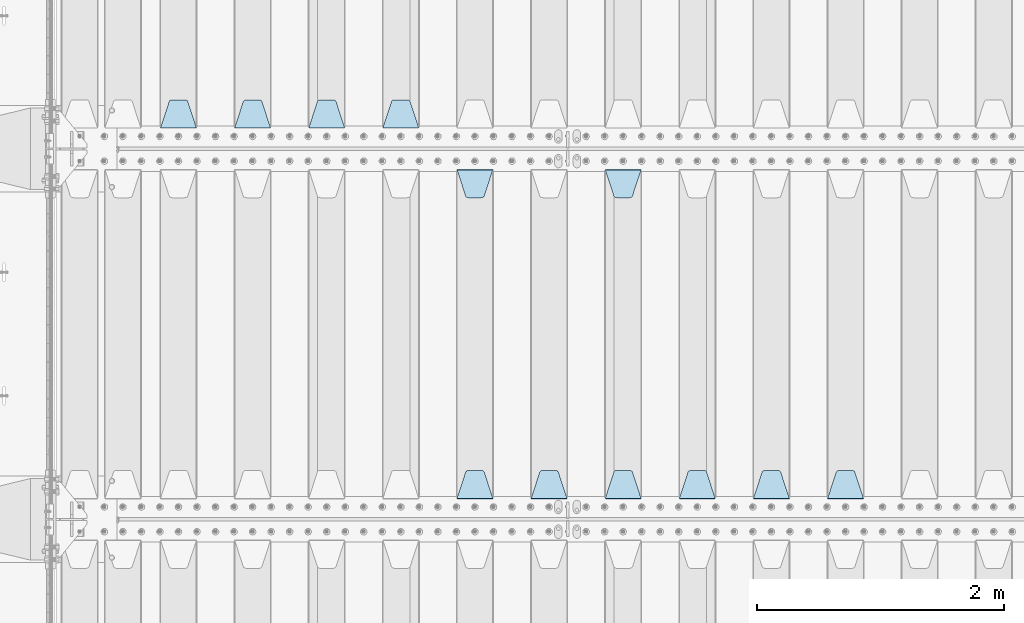
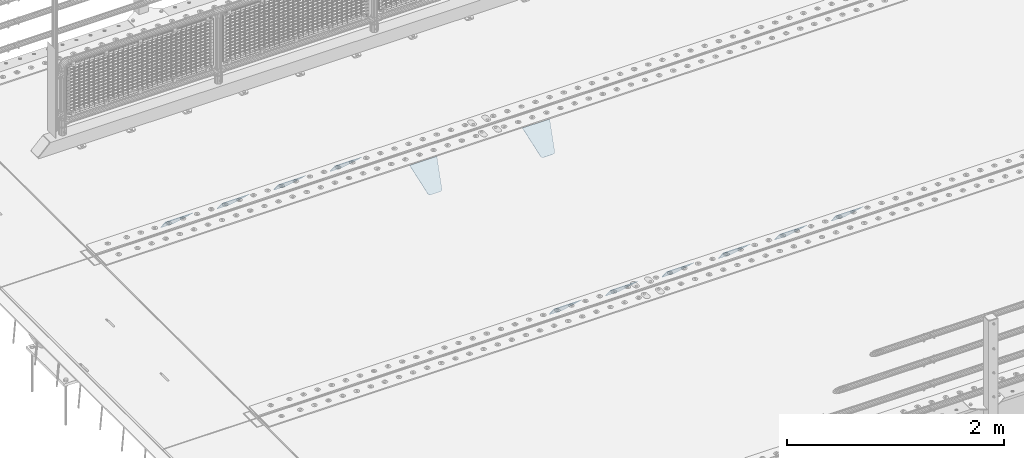
# One storey, part 179 of 219: 12 plates.
"""IFC2X3 building model written with IfcOpenShell, lengths in millimetres."""

from ifc_helpers import new_model, si_unit, frame, origin_with_axes, place, context, subcontext, project, spatial, faceted_brep, material, type_object, element, save


model = new_model("IFC2X3")

# Units and contexts
model_context = context("Model", 3, precision=1e-05, world=origin_with_axes())
body_context = subcontext(model_context, "Body", "Model", "MODEL_VIEW")
ifc_project = project(units=[si_unit("LENGTHUNIT", "METRE", prefix="MILLI"), si_unit("AREAUNIT", "SQUARE_METRE"), si_unit("VOLUMEUNIT", "CUBIC_METRE"), si_unit("MASSUNIT", "GRAM", prefix="KILO"), si_unit("TIMEUNIT", "SECOND"), si_unit("PLANEANGLEUNIT", "RADIAN"), si_unit("SOLIDANGLEUNIT", "STERADIAN"), si_unit("THERMODYNAMICTEMPERATUREUNIT", "DEGREE_CELSIUS"), si_unit("LUMINOUSINTENSITYUNIT", "LUMEN")], contexts=[model_context])

# Site, building, storey
site_placement = place(None, origin_with_axes())
site = spatial("IfcSite", under=ifc_project, at=site_placement, CompositionType="ELEMENT")
building_placement = place(site_placement, origin_with_axes())
building = spatial("IfcBuilding", under=site, at=building_placement, Name="Standard", CompositionType="ELEMENT")
storey_placement = place(building_placement, origin_with_axes())
storey = spatial("IfcBuildingStorey", under=building, at=storey_placement, Name="Undefined", CompositionType="ELEMENT", Elevation=0.0)

# Plates
ifc_material = material(Name="STEEL/S355N")
plate_type = type_object("IfcPlateType", PredefinedType="NOTDEFINED")
plate_1_placement = place(storey_placement, frame((6545.0, 27168.232233047, -1.76776695296758), z_axis=(0.0, 0.707106781186547, -0.707106781186548), x_axis=(-1.0, 0.0, 0.0)))
element("IfcPlate", 1, at=plate_1_placement, inside=storey, type_object=plate_type, material=ifc_material, context=body_context, shape_type="Brep", body=[
    faceted_brep([(0.0, -2.5, 0.0), (69.345504679477, -2.5, 300.171731424834), (69.345504679477, 2.49999999999636, 300.171731424831), (0.0, 2.5, 0.0), (70.9274061199576, -2.50000000000364, 304.8974424154), (70.9274061199576, 2.49999999999636, 304.8974424154), (73.3818627772307, -2.50000000000364, 309.234538108532), (73.3818627772307, 2.49999999999636, 309.234538108532), (76.6187032999569, -2.50000000000364, 313.023683126106), (76.6187032999569, 2.49999999999636, 313.023683126106), (80.5190132704993, -2.50000000000364, 316.125672595372), (80.5190132704993, 2.49999999999636, 316.125672595372), (84.9395038596831, -2.50000000000364, 318.426546230476), (84.9395038596831, 2.5, 318.426546230479), (89.7177759439237, -2.50000000000364, 319.841774983277), (89.7177759439237, 2.5, 319.841774983281), (94.6782862926502, -2.50000000000364, 320.319366455078), (94.6782862926502, 2.49999999999636, 320.319366455078), (195.32171370735, -2.50000000000364, 320.319366455078), (195.32171370735, 2.49999999999636, 320.319366455078), (200.282224056076, -2.50000000000364, 319.841774983277), (200.282224056076, 2.5, 319.841774983281), (205.060496140317, -2.50000000000364, 318.426546230476), (205.060496140317, 2.49999999999636, 318.426546230476), (209.480986729501, -2.50000000000364, 316.125672595372), (209.480986729501, 2.49999999999636, 316.125672595372), (213.381296700043, -2.50000000000364, 313.023683126106), (213.381296700043, 2.49999999999272, 313.023683126106), (216.618137222769, -2.50000000000364, 309.234538108529), (216.618137222769, 2.49999999999636, 309.234538108525), (219.072593880042, -2.50000000000364, 304.8974424154), (219.072593880042, 2.49999999999636, 304.8974424154), (220.654495320523, -2.5, 300.171731424834), (220.654495320523, 2.49999999999636, 300.171731424831), (290.0, -2.50000000000364, 3.63797880709171e-12), (290.0, 2.49999999999636, 0.0)], [[[0, 1, 2, 3]], [[1, 4, 5, 2]], [[4, 6, 7, 5]], [[6, 8, 9, 7]], [[8, 10, 11, 9]], [[10, 12, 13, 11]], [[12, 14, 15, 13]], [[14, 16, 17, 15]], [[16, 18, 19, 17]], [[18, 20, 21, 19]], [[20, 22, 23, 21]], [[22, 24, 25, 23]], [[24, 26, 27, 25]], [[26, 28, 29, 27]], [[28, 30, 31, 29]], [[30, 32, 33, 31]], [[32, 34, 35, 33]], [[34, 0, 3, 35]], [[5, 7, 9, 11, 13, 15, 17, 19, 21, 23, 25, 27, 29, 31, 33, 35, 3, 2]], [[34, 32, 30, 28, 26, 24, 22, 20, 18, 16, 14, 12, 10, 8, 6, 4, 1, 0]]]),
])
plate_2_placement = place(storey_placement, frame((5945.0, 27168.232233047, -1.76776695296758), z_axis=(0.0, 0.707106781186547, -0.707106781186548), x_axis=(-1.0, 0.0, 0.0)))
element("IfcPlate", 2, at=plate_2_placement, inside=storey, type_object=plate_type, material=ifc_material, context=body_context, shape_type="Brep", body=[
    faceted_brep([(0.0, -2.5, 0.0), (69.345504679477, -2.5, 300.171731424834), (69.345504679477, 2.49999999999636, 300.171731424831), (0.0, 2.5, 0.0), (70.9274061199576, -2.50000000000364, 304.8974424154), (70.9274061199576, 2.49999999999636, 304.8974424154), (73.3818627772307, -2.50000000000364, 309.234538108532), (73.3818627772307, 2.49999999999636, 309.234538108532), (76.6187032999569, -2.50000000000364, 313.023683126106), (76.6187032999569, 2.49999999999636, 313.023683126106), (80.5190132704993, -2.50000000000364, 316.125672595372), (80.5190132704993, 2.49999999999636, 316.125672595372), (84.9395038596831, -2.50000000000364, 318.426546230476), (84.9395038596831, 2.5, 318.426546230479), (89.7177759439237, -2.50000000000364, 319.841774983277), (89.7177759439237, 2.5, 319.841774983281), (94.6782862926502, -2.50000000000364, 320.319366455078), (94.6782862926502, 2.49999999999636, 320.319366455078), (195.32171370735, -2.50000000000364, 320.319366455078), (195.32171370735, 2.49999999999636, 320.319366455078), (200.282224056076, -2.50000000000364, 319.841774983277), (200.282224056076, 2.5, 319.841774983281), (205.060496140317, -2.50000000000364, 318.426546230476), (205.060496140317, 2.49999999999636, 318.426546230476), (209.480986729501, -2.50000000000364, 316.125672595372), (209.480986729501, 2.49999999999636, 316.125672595372), (213.381296700043, -2.50000000000364, 313.023683126106), (213.381296700043, 2.49999999999272, 313.023683126106), (216.618137222769, -2.50000000000364, 309.234538108529), (216.618137222769, 2.49999999999636, 309.234538108525), (219.072593880042, -2.50000000000364, 304.8974424154), (219.072593880042, 2.49999999999636, 304.8974424154), (220.654495320523, -2.5, 300.171731424834), (220.654495320523, 2.49999999999636, 300.171731424831), (290.0, -2.50000000000364, 3.63797880709171e-12), (290.0, 2.49999999999636, 0.0)], [[[0, 1, 2, 3]], [[1, 4, 5, 2]], [[4, 6, 7, 5]], [[6, 8, 9, 7]], [[8, 10, 11, 9]], [[10, 12, 13, 11]], [[12, 14, 15, 13]], [[14, 16, 17, 15]], [[16, 18, 19, 17]], [[18, 20, 21, 19]], [[20, 22, 23, 21]], [[22, 24, 25, 23]], [[24, 26, 27, 25]], [[26, 28, 29, 27]], [[28, 30, 31, 29]], [[30, 32, 33, 31]], [[32, 34, 35, 33]], [[34, 0, 3, 35]], [[5, 7, 9, 11, 13, 15, 17, 19, 21, 23, 25, 27, 29, 31, 33, 35, 3, 2]], [[34, 32, 30, 28, 26, 24, 22, 20, 18, 16, 14, 12, 10, 8, 6, 4, 1, 0]]]),
])
plate_3_placement = place(storey_placement, frame((5345.0, 27168.232233047, -1.76776695296758), z_axis=(0.0, 0.707106781186547, -0.707106781186548), x_axis=(-1.0, 0.0, 0.0)))
element("IfcPlate", 3, at=plate_3_placement, inside=storey, type_object=plate_type, material=ifc_material, context=body_context, shape_type="Brep", body=[
    faceted_brep([(0.0, -2.5, 0.0), (69.345504679477, -2.5, 300.171731424834), (69.345504679477, 2.49999999999636, 300.171731424831), (0.0, 2.5, 0.0), (70.9274061199576, -2.50000000000364, 304.8974424154), (70.9274061199576, 2.49999999999636, 304.8974424154), (73.3818627772307, -2.50000000000364, 309.234538108532), (73.3818627772307, 2.49999999999636, 309.234538108532), (76.6187032999569, -2.50000000000364, 313.023683126106), (76.6187032999569, 2.49999999999636, 313.023683126106), (80.5190132704993, -2.50000000000364, 316.125672595372), (80.5190132704993, 2.49999999999636, 316.125672595372), (84.9395038596831, -2.50000000000364, 318.426546230476), (84.9395038596831, 2.5, 318.426546230479), (89.7177759439237, -2.50000000000364, 319.841774983277), (89.7177759439237, 2.5, 319.841774983281), (94.6782862926502, -2.50000000000364, 320.319366455078), (94.6782862926502, 2.49999999999636, 320.319366455078), (195.32171370735, -2.50000000000364, 320.319366455078), (195.32171370735, 2.49999999999636, 320.319366455078), (200.282224056076, -2.50000000000364, 319.841774983277), (200.282224056076, 2.5, 319.841774983281), (205.060496140317, -2.50000000000364, 318.426546230476), (205.060496140317, 2.49999999999636, 318.426546230476), (209.480986729501, -2.50000000000364, 316.125672595372), (209.480986729501, 2.49999999999636, 316.125672595372), (213.381296700043, -2.50000000000364, 313.023683126106), (213.381296700043, 2.49999999999272, 313.023683126106), (216.618137222769, -2.50000000000364, 309.234538108529), (216.618137222769, 2.49999999999636, 309.234538108525), (219.072593880042, -2.50000000000364, 304.8974424154), (219.072593880042, 2.49999999999636, 304.8974424154), (220.654495320523, -2.5, 300.171731424834), (220.654495320523, 2.49999999999636, 300.171731424831), (290.0, -2.50000000000364, 3.63797880709171e-12), (290.0, 2.49999999999636, 0.0)], [[[0, 1, 2, 3]], [[1, 4, 5, 2]], [[4, 6, 7, 5]], [[6, 8, 9, 7]], [[8, 10, 11, 9]], [[10, 12, 13, 11]], [[12, 14, 15, 13]], [[14, 16, 17, 15]], [[16, 18, 19, 17]], [[18, 20, 21, 19]], [[20, 22, 23, 21]], [[22, 24, 25, 23]], [[24, 26, 27, 25]], [[26, 28, 29, 27]], [[28, 30, 31, 29]], [[30, 32, 33, 31]], [[32, 34, 35, 33]], [[34, 0, 3, 35]], [[5, 7, 9, 11, 13, 15, 17, 19, 21, 23, 25, 27, 29, 31, 33, 35, 3, 2]], [[34, 32, 30, 28, 26, 24, 22, 20, 18, 16, 14, 12, 10, 8, 6, 4, 1, 0]]]),
])
plate_4_placement = place(storey_placement, frame((4455.0, 29831.767766956, -1.76776695296758), z_axis=(0.0, -0.707106781186547, -0.707106781186548), x_axis=(1.0, 0.0, 0.0)))
element("IfcPlate", 4, at=plate_4_placement, inside=storey, type_object=plate_type, material=ifc_material, context=body_context, shape_type="Brep", body=[
    faceted_brep([(0.0, -2.5, 0.0), (69.345504679477, -2.5, 300.171731424834), (69.345504679477, 2.49999999999636, 300.171731424831), (0.0, 2.5, 0.0), (70.9274061199576, -2.50000000000364, 304.8974424154), (70.9274061199576, 2.49999999999636, 304.8974424154), (73.3818627772307, -2.50000000000364, 309.234538108532), (73.3818627772307, 2.49999999999636, 309.234538108532), (76.6187032999569, -2.50000000000364, 313.023683126106), (76.6187032999569, 2.49999999999636, 313.023683126106), (80.5190132704993, -2.50000000000364, 316.125672595372), (80.5190132704993, 2.49999999999636, 316.125672595372), (84.9395038596831, -2.50000000000364, 318.426546230476), (84.9395038596831, 2.5, 318.426546230479), (89.7177759439237, -2.50000000000364, 319.841774983277), (89.7177759439237, 2.5, 319.841774983281), (94.6782862926502, -2.50000000000364, 320.319366455078), (94.6782862926502, 2.49999999999636, 320.319366455078), (195.32171370735, -2.50000000000364, 320.319366455078), (195.32171370735, 2.49999999999636, 320.319366455078), (200.282224056076, -2.50000000000364, 319.841774983277), (200.282224056076, 2.5, 319.841774983281), (205.060496140317, -2.50000000000364, 318.426546230476), (205.060496140317, 2.49999999999636, 318.426546230476), (209.480986729501, -2.50000000000364, 316.125672595372), (209.480986729501, 2.49999999999636, 316.125672595372), (213.381296700043, -2.50000000000364, 313.023683126106), (213.381296700043, 2.49999999999272, 313.023683126106), (216.618137222769, -2.50000000000364, 309.234538108529), (216.618137222769, 2.49999999999636, 309.234538108525), (219.072593880042, -2.50000000000364, 304.8974424154), (219.072593880042, 2.49999999999636, 304.8974424154), (220.654495320523, -2.5, 300.171731424834), (220.654495320523, 2.49999999999636, 300.171731424831), (290.0, -2.50000000000364, 3.63797880709171e-12), (290.0, 2.49999999999636, 0.0)], [[[0, 1, 2, 3]], [[1, 4, 5, 2]], [[4, 6, 7, 5]], [[6, 8, 9, 7]], [[8, 10, 11, 9]], [[10, 12, 13, 11]], [[12, 14, 15, 13]], [[14, 16, 17, 15]], [[16, 18, 19, 17]], [[18, 20, 21, 19]], [[20, 22, 23, 21]], [[22, 24, 25, 23]], [[24, 26, 27, 25]], [[26, 28, 29, 27]], [[28, 30, 31, 29]], [[30, 32, 33, 31]], [[32, 34, 35, 33]], [[34, 0, 3, 35]], [[5, 7, 9, 11, 13, 15, 17, 19, 21, 23, 25, 27, 29, 31, 33, 35, 3, 2]], [[34, 32, 30, 28, 26, 24, 22, 20, 18, 16, 14, 12, 10, 8, 6, 4, 1, 0]]]),
])
plate_5_placement = place(storey_placement, frame((4745.0, 27168.232233047, -1.76776695296758), z_axis=(0.0, 0.707106781186547, -0.707106781186548), x_axis=(-1.0, 0.0, 0.0)))
element("IfcPlate", 5, at=plate_5_placement, inside=storey, type_object=plate_type, material=ifc_material, context=body_context, shape_type="Brep", body=[
    faceted_brep([(0.0, -2.5, 0.0), (69.345504679477, -2.5, 300.171731424834), (69.345504679477, 2.49999999999636, 300.171731424831), (0.0, 2.5, 0.0), (70.9274061199576, -2.50000000000364, 304.8974424154), (70.9274061199576, 2.49999999999636, 304.8974424154), (73.3818627772307, -2.50000000000364, 309.234538108532), (73.3818627772307, 2.49999999999636, 309.234538108532), (76.6187032999569, -2.50000000000364, 313.023683126106), (76.6187032999569, 2.49999999999636, 313.023683126106), (80.5190132704993, -2.50000000000364, 316.125672595372), (80.5190132704993, 2.49999999999636, 316.125672595372), (84.9395038596831, -2.50000000000364, 318.426546230476), (84.9395038596831, 2.5, 318.426546230479), (89.7177759439237, -2.50000000000364, 319.841774983277), (89.7177759439237, 2.5, 319.841774983281), (94.6782862926502, -2.50000000000364, 320.319366455078), (94.6782862926502, 2.49999999999636, 320.319366455078), (195.32171370735, -2.50000000000364, 320.319366455078), (195.32171370735, 2.49999999999636, 320.319366455078), (200.282224056076, -2.50000000000364, 319.841774983277), (200.282224056076, 2.5, 319.841774983281), (205.060496140317, -2.50000000000364, 318.426546230476), (205.060496140317, 2.49999999999636, 318.426546230476), (209.480986729501, -2.50000000000364, 316.125672595372), (209.480986729501, 2.49999999999636, 316.125672595372), (213.381296700043, -2.50000000000364, 313.023683126106), (213.381296700043, 2.49999999999272, 313.023683126106), (216.618137222769, -2.50000000000364, 309.234538108529), (216.618137222769, 2.49999999999636, 309.234538108525), (219.072593880042, -2.50000000000364, 304.8974424154), (219.072593880042, 2.49999999999636, 304.8974424154), (220.654495320523, -2.5, 300.171731424834), (220.654495320523, 2.49999999999636, 300.171731424831), (290.0, -2.50000000000364, 3.63797880709171e-12), (290.0, 2.49999999999636, 0.0)], [[[0, 1, 2, 3]], [[1, 4, 5, 2]], [[4, 6, 7, 5]], [[6, 8, 9, 7]], [[8, 10, 11, 9]], [[10, 12, 13, 11]], [[12, 14, 15, 13]], [[14, 16, 17, 15]], [[16, 18, 19, 17]], [[18, 20, 21, 19]], [[20, 22, 23, 21]], [[22, 24, 25, 23]], [[24, 26, 27, 25]], [[26, 28, 29, 27]], [[28, 30, 31, 29]], [[30, 32, 33, 31]], [[32, 34, 35, 33]], [[34, 0, 3, 35]], [[5, 7, 9, 11, 13, 15, 17, 19, 21, 23, 25, 27, 29, 31, 33, 35, 3, 2]], [[34, 32, 30, 28, 26, 24, 22, 20, 18, 16, 14, 12, 10, 8, 6, 4, 1, 0]]]),
])
plate_6_placement = place(storey_placement, frame((4145.0, 27168.232233047, -1.76776695296758), z_axis=(0.0, 0.707106781186547, -0.707106781186548), x_axis=(-1.0, 0.0, 0.0)))
element("IfcPlate", 6, at=plate_6_placement, inside=storey, type_object=plate_type, material=ifc_material, context=body_context, shape_type="Brep", body=[
    faceted_brep([(0.0, -2.5, 0.0), (69.345504679477, -2.5, 300.171731424834), (69.345504679477, 2.49999999999636, 300.171731424831), (0.0, 2.5, 0.0), (70.9274061199576, -2.50000000000364, 304.8974424154), (70.9274061199576, 2.49999999999636, 304.8974424154), (73.3818627772307, -2.50000000000364, 309.234538108532), (73.3818627772307, 2.49999999999636, 309.234538108532), (76.6187032999569, -2.50000000000364, 313.023683126106), (76.6187032999569, 2.49999999999636, 313.023683126106), (80.5190132704993, -2.50000000000364, 316.125672595372), (80.5190132704993, 2.49999999999636, 316.125672595372), (84.9395038596831, -2.50000000000364, 318.426546230476), (84.9395038596831, 2.5, 318.426546230479), (89.7177759439237, -2.50000000000364, 319.841774983277), (89.7177759439237, 2.5, 319.841774983281), (94.6782862926502, -2.50000000000364, 320.319366455078), (94.6782862926502, 2.49999999999636, 320.319366455078), (195.32171370735, -2.50000000000364, 320.319366455078), (195.32171370735, 2.49999999999636, 320.319366455078), (200.282224056076, -2.50000000000364, 319.841774983277), (200.282224056076, 2.5, 319.841774983281), (205.060496140317, -2.50000000000364, 318.426546230476), (205.060496140317, 2.49999999999636, 318.426546230476), (209.480986729501, -2.50000000000364, 316.125672595372), (209.480986729501, 2.49999999999636, 316.125672595372), (213.381296700043, -2.50000000000364, 313.023683126106), (213.381296700043, 2.49999999999272, 313.023683126106), (216.618137222769, -2.50000000000364, 309.234538108529), (216.618137222769, 2.49999999999636, 309.234538108525), (219.072593880042, -2.50000000000364, 304.8974424154), (219.072593880042, 2.49999999999636, 304.8974424154), (220.654495320523, -2.5, 300.171731424834), (220.654495320523, 2.49999999999636, 300.171731424831), (290.0, -2.50000000000364, 3.63797880709171e-12), (290.0, 2.49999999999636, 0.0)], [[[0, 1, 2, 3]], [[1, 4, 5, 2]], [[4, 6, 7, 5]], [[6, 8, 9, 7]], [[8, 10, 11, 9]], [[10, 12, 13, 11]], [[12, 14, 15, 13]], [[14, 16, 17, 15]], [[16, 18, 19, 17]], [[18, 20, 21, 19]], [[20, 22, 23, 21]], [[22, 24, 25, 23]], [[24, 26, 27, 25]], [[26, 28, 29, 27]], [[28, 30, 31, 29]], [[30, 32, 33, 31]], [[32, 34, 35, 33]], [[34, 0, 3, 35]], [[5, 7, 9, 11, 13, 15, 17, 19, 21, 23, 25, 27, 29, 31, 33, 35, 3, 2]], [[34, 32, 30, 28, 26, 24, 22, 20, 18, 16, 14, 12, 10, 8, 6, 4, 1, 0]]]),
])
plate_7_placement = place(storey_placement, frame((3255.0, 29831.767766956, -1.76776695296758), z_axis=(0.0, -0.707106781186547, -0.707106781186548), x_axis=(1.0, 0.0, 0.0)))
element("IfcPlate", 7, at=plate_7_placement, inside=storey, type_object=plate_type, material=ifc_material, context=body_context, shape_type="Brep", body=[
    faceted_brep([(0.0, -2.5, 0.0), (69.345504679477, -2.5, 300.171731424834), (69.345504679477, 2.49999999999636, 300.171731424831), (0.0, 2.5, 0.0), (70.9274061199576, -2.50000000000364, 304.8974424154), (70.9274061199576, 2.49999999999636, 304.8974424154), (73.3818627772307, -2.50000000000364, 309.234538108532), (73.3818627772307, 2.49999999999636, 309.234538108532), (76.6187032999569, -2.50000000000364, 313.023683126106), (76.6187032999569, 2.49999999999636, 313.023683126106), (80.5190132704993, -2.50000000000364, 316.125672595372), (80.5190132704993, 2.49999999999636, 316.125672595372), (84.9395038596831, -2.50000000000364, 318.426546230476), (84.9395038596831, 2.5, 318.426546230479), (89.7177759439237, -2.50000000000364, 319.841774983277), (89.7177759439237, 2.5, 319.841774983281), (94.6782862926502, -2.50000000000364, 320.319366455078), (94.6782862926502, 2.49999999999636, 320.319366455078), (195.32171370735, -2.50000000000364, 320.319366455078), (195.32171370735, 2.49999999999636, 320.319366455078), (200.282224056076, -2.50000000000364, 319.841774983277), (200.282224056076, 2.5, 319.841774983281), (205.060496140317, -2.50000000000364, 318.426546230476), (205.060496140317, 2.49999999999636, 318.426546230476), (209.480986729501, -2.50000000000364, 316.125672595372), (209.480986729501, 2.49999999999636, 316.125672595372), (213.381296700043, -2.50000000000364, 313.023683126106), (213.381296700043, 2.49999999999272, 313.023683126106), (216.618137222769, -2.50000000000364, 309.234538108529), (216.618137222769, 2.49999999999636, 309.234538108525), (219.072593880042, -2.50000000000364, 304.8974424154), (219.072593880042, 2.49999999999636, 304.8974424154), (220.654495320523, -2.5, 300.171731424834), (220.654495320523, 2.49999999999636, 300.171731424831), (290.0, -2.50000000000364, 3.63797880709171e-12), (290.0, 2.49999999999636, 0.0)], [[[0, 1, 2, 3]], [[1, 4, 5, 2]], [[4, 6, 7, 5]], [[6, 8, 9, 7]], [[8, 10, 11, 9]], [[10, 12, 13, 11]], [[12, 14, 15, 13]], [[14, 16, 17, 15]], [[16, 18, 19, 17]], [[18, 20, 21, 19]], [[20, 22, 23, 21]], [[22, 24, 25, 23]], [[24, 26, 27, 25]], [[26, 28, 29, 27]], [[28, 30, 31, 29]], [[30, 32, 33, 31]], [[32, 34, 35, 33]], [[34, 0, 3, 35]], [[5, 7, 9, 11, 13, 15, 17, 19, 21, 23, 25, 27, 29, 31, 33, 35, 3, 2]], [[34, 32, 30, 28, 26, 24, 22, 20, 18, 16, 14, 12, 10, 8, 6, 4, 1, 0]]]),
])
plate_8_placement = place(storey_placement, frame((3545.0, 27168.232233047, -1.76776695296758), z_axis=(0.0, 0.707106781186547, -0.707106781186548), x_axis=(-1.0, 0.0, 0.0)))
element("IfcPlate", 8, at=plate_8_placement, inside=storey, type_object=plate_type, material=ifc_material, context=body_context, shape_type="Brep", body=[
    faceted_brep([(0.0, -2.5, 0.0), (69.345504679477, -2.5, 300.171731424834), (69.345504679477, 2.49999999999636, 300.171731424831), (0.0, 2.5, 0.0), (70.9274061199576, -2.50000000000364, 304.8974424154), (70.9274061199576, 2.49999999999636, 304.8974424154), (73.3818627772307, -2.50000000000364, 309.234538108532), (73.3818627772307, 2.49999999999636, 309.234538108532), (76.6187032999569, -2.50000000000364, 313.023683126106), (76.6187032999569, 2.49999999999636, 313.023683126106), (80.5190132704993, -2.50000000000364, 316.125672595372), (80.5190132704993, 2.49999999999636, 316.125672595372), (84.9395038596831, -2.50000000000364, 318.426546230476), (84.9395038596831, 2.5, 318.426546230479), (89.7177759439237, -2.50000000000364, 319.841774983277), (89.7177759439237, 2.5, 319.841774983281), (94.6782862926502, -2.50000000000364, 320.319366455078), (94.6782862926502, 2.49999999999636, 320.319366455078), (195.32171370735, -2.50000000000364, 320.319366455078), (195.32171370735, 2.49999999999636, 320.319366455078), (200.282224056076, -2.50000000000364, 319.841774983277), (200.282224056076, 2.5, 319.841774983281), (205.060496140317, -2.50000000000364, 318.426546230476), (205.060496140317, 2.49999999999636, 318.426546230476), (209.480986729501, -2.50000000000364, 316.125672595372), (209.480986729501, 2.49999999999636, 316.125672595372), (213.381296700043, -2.50000000000364, 313.023683126106), (213.381296700043, 2.49999999999272, 313.023683126106), (216.618137222769, -2.50000000000364, 309.234538108529), (216.618137222769, 2.49999999999636, 309.234538108525), (219.072593880042, -2.50000000000364, 304.8974424154), (219.072593880042, 2.49999999999636, 304.8974424154), (220.654495320523, -2.5, 300.171731424834), (220.654495320523, 2.49999999999636, 300.171731424831), (290.0, -2.50000000000364, 3.63797880709171e-12), (290.0, 2.49999999999636, 0.0)], [[[0, 1, 2, 3]], [[1, 4, 5, 2]], [[4, 6, 7, 5]], [[6, 8, 9, 7]], [[8, 10, 11, 9]], [[10, 12, 13, 11]], [[12, 14, 15, 13]], [[14, 16, 17, 15]], [[16, 18, 19, 17]], [[18, 20, 21, 19]], [[20, 22, 23, 21]], [[22, 24, 25, 23]], [[24, 26, 27, 25]], [[26, 28, 29, 27]], [[28, 30, 31, 29]], [[30, 32, 33, 31]], [[32, 34, 35, 33]], [[34, 0, 3, 35]], [[5, 7, 9, 11, 13, 15, 17, 19, 21, 23, 25, 27, 29, 31, 33, 35, 3, 2]], [[34, 32, 30, 28, 26, 24, 22, 20, 18, 16, 14, 12, 10, 8, 6, 4, 1, 0]]]),
])
plate_9_placement = place(storey_placement, frame((2945.0, 30168.232233047, -1.76776695296758), z_axis=(0.0, 0.707106781186547, -0.707106781186548), x_axis=(-1.0, 0.0, 0.0)))
element("IfcPlate", 9, at=plate_9_placement, inside=storey, type_object=plate_type, material=ifc_material, context=body_context, shape_type="Brep", body=[
    faceted_brep([(0.0, -2.5, 0.0), (69.345504679477, -2.5, 300.171731424834), (69.345504679477, 2.49999999999636, 300.171731424831), (0.0, 2.5, 0.0), (70.9274061199576, -2.50000000000364, 304.8974424154), (70.9274061199576, 2.49999999999636, 304.8974424154), (73.3818627772307, -2.50000000000364, 309.234538108532), (73.3818627772307, 2.49999999999636, 309.234538108532), (76.6187032999569, -2.50000000000364, 313.023683126106), (76.6187032999569, 2.49999999999636, 313.023683126106), (80.5190132704993, -2.50000000000364, 316.125672595372), (80.5190132704993, 2.49999999999636, 316.125672595372), (84.9395038596831, -2.50000000000364, 318.426546230476), (84.9395038596831, 2.5, 318.426546230479), (89.7177759439237, -2.50000000000364, 319.841774983277), (89.7177759439237, 2.5, 319.841774983281), (94.6782862926502, -2.50000000000364, 320.319366455078), (94.6782862926502, 2.49999999999636, 320.319366455078), (195.32171370735, -2.50000000000364, 320.319366455078), (195.32171370735, 2.49999999999636, 320.319366455078), (200.282224056076, -2.50000000000364, 319.841774983277), (200.282224056076, 2.5, 319.841774983281), (205.060496140317, -2.50000000000364, 318.426546230476), (205.060496140317, 2.49999999999636, 318.426546230476), (209.480986729501, -2.50000000000364, 316.125672595372), (209.480986729501, 2.49999999999636, 316.125672595372), (213.381296700043, -2.50000000000364, 313.023683126106), (213.381296700043, 2.49999999999272, 313.023683126106), (216.618137222769, -2.50000000000364, 309.234538108529), (216.618137222769, 2.49999999999636, 309.234538108525), (219.072593880042, -2.50000000000364, 304.8974424154), (219.072593880042, 2.49999999999636, 304.8974424154), (220.654495320523, -2.5, 300.171731424834), (220.654495320523, 2.49999999999636, 300.171731424831), (290.0, -2.50000000000364, 3.63797880709171e-12), (290.0, 2.49999999999636, 0.0)], [[[0, 1, 2, 3]], [[1, 4, 5, 2]], [[4, 6, 7, 5]], [[6, 8, 9, 7]], [[8, 10, 11, 9]], [[10, 12, 13, 11]], [[12, 14, 15, 13]], [[14, 16, 17, 15]], [[16, 18, 19, 17]], [[18, 20, 21, 19]], [[20, 22, 23, 21]], [[22, 24, 25, 23]], [[24, 26, 27, 25]], [[26, 28, 29, 27]], [[28, 30, 31, 29]], [[30, 32, 33, 31]], [[32, 34, 35, 33]], [[34, 0, 3, 35]], [[5, 7, 9, 11, 13, 15, 17, 19, 21, 23, 25, 27, 29, 31, 33, 35, 3, 2]], [[34, 32, 30, 28, 26, 24, 22, 20, 18, 16, 14, 12, 10, 8, 6, 4, 1, 0]]]),
])
plate_10_placement = place(storey_placement, frame((2345.0, 30168.232233047, -1.76776695296758), z_axis=(0.0, 0.707106781186547, -0.707106781186548), x_axis=(-1.0, 0.0, 0.0)))
element("IfcPlate", 10, at=plate_10_placement, inside=storey, type_object=plate_type, material=ifc_material, context=body_context, shape_type="Brep", body=[
    faceted_brep([(0.0, -2.5, 0.0), (69.345504679477, -2.5, 300.171731424834), (69.345504679477, 2.49999999999636, 300.171731424831), (0.0, 2.5, 0.0), (70.9274061199576, -2.50000000000364, 304.8974424154), (70.9274061199576, 2.49999999999636, 304.8974424154), (73.3818627772307, -2.50000000000364, 309.234538108532), (73.3818627772307, 2.49999999999636, 309.234538108532), (76.6187032999569, -2.50000000000364, 313.023683126106), (76.6187032999569, 2.49999999999636, 313.023683126106), (80.5190132704993, -2.50000000000364, 316.125672595372), (80.5190132704993, 2.49999999999636, 316.125672595372), (84.9395038596831, -2.50000000000364, 318.426546230476), (84.9395038596831, 2.5, 318.426546230479), (89.7177759439237, -2.50000000000364, 319.841774983277), (89.7177759439237, 2.5, 319.841774983281), (94.6782862926502, -2.50000000000364, 320.319366455078), (94.6782862926502, 2.49999999999636, 320.319366455078), (195.32171370735, -2.50000000000364, 320.319366455078), (195.32171370735, 2.49999999999636, 320.319366455078), (200.282224056076, -2.50000000000364, 319.841774983277), (200.282224056076, 2.5, 319.841774983281), (205.060496140317, -2.50000000000364, 318.426546230476), (205.060496140317, 2.49999999999636, 318.426546230476), (209.480986729501, -2.50000000000364, 316.125672595372), (209.480986729501, 2.49999999999636, 316.125672595372), (213.381296700043, -2.50000000000364, 313.023683126106), (213.381296700043, 2.49999999999272, 313.023683126106), (216.618137222769, -2.50000000000364, 309.234538108529), (216.618137222769, 2.49999999999636, 309.234538108525), (219.072593880042, -2.50000000000364, 304.8974424154), (219.072593880042, 2.49999999999636, 304.8974424154), (220.654495320523, -2.5, 300.171731424834), (220.654495320523, 2.49999999999636, 300.171731424831), (290.0, -2.50000000000364, 3.63797880709171e-12), (290.0, 2.49999999999636, 0.0)], [[[0, 1, 2, 3]], [[1, 4, 5, 2]], [[4, 6, 7, 5]], [[6, 8, 9, 7]], [[8, 10, 11, 9]], [[10, 12, 13, 11]], [[12, 14, 15, 13]], [[14, 16, 17, 15]], [[16, 18, 19, 17]], [[18, 20, 21, 19]], [[20, 22, 23, 21]], [[22, 24, 25, 23]], [[24, 26, 27, 25]], [[26, 28, 29, 27]], [[28, 30, 31, 29]], [[30, 32, 33, 31]], [[32, 34, 35, 33]], [[34, 0, 3, 35]], [[5, 7, 9, 11, 13, 15, 17, 19, 21, 23, 25, 27, 29, 31, 33, 35, 3, 2]], [[34, 32, 30, 28, 26, 24, 22, 20, 18, 16, 14, 12, 10, 8, 6, 4, 1, 0]]]),
])
plate_11_placement = place(storey_placement, frame((1745.0, 30168.232233047, -1.76776695296758), z_axis=(0.0, 0.707106781186547, -0.707106781186548), x_axis=(-1.0, 0.0, 0.0)))
element("IfcPlate", 11, at=plate_11_placement, inside=storey, type_object=plate_type, material=ifc_material, context=body_context, shape_type="Brep", body=[
    faceted_brep([(0.0, -2.5, 0.0), (69.345504679477, -2.5, 300.171731424834), (69.345504679477, 2.49999999999636, 300.171731424831), (0.0, 2.5, 0.0), (70.9274061199576, -2.50000000000364, 304.8974424154), (70.9274061199576, 2.49999999999636, 304.8974424154), (73.3818627772307, -2.50000000000364, 309.234538108532), (73.3818627772307, 2.49999999999636, 309.234538108532), (76.6187032999569, -2.50000000000364, 313.023683126106), (76.6187032999569, 2.49999999999636, 313.023683126106), (80.5190132704993, -2.50000000000364, 316.125672595372), (80.5190132704993, 2.49999999999636, 316.125672595372), (84.9395038596831, -2.50000000000364, 318.426546230476), (84.9395038596831, 2.5, 318.426546230479), (89.7177759439237, -2.50000000000364, 319.841774983277), (89.7177759439237, 2.5, 319.841774983281), (94.6782862926502, -2.50000000000364, 320.319366455078), (94.6782862926502, 2.49999999999636, 320.319366455078), (195.32171370735, -2.50000000000364, 320.319366455078), (195.32171370735, 2.49999999999636, 320.319366455078), (200.282224056076, -2.50000000000364, 319.841774983277), (200.282224056076, 2.5, 319.841774983281), (205.060496140317, -2.50000000000364, 318.426546230476), (205.060496140317, 2.49999999999636, 318.426546230476), (209.480986729501, -2.50000000000364, 316.125672595372), (209.480986729501, 2.49999999999636, 316.125672595372), (213.381296700043, -2.50000000000364, 313.023683126106), (213.381296700043, 2.49999999999272, 313.023683126106), (216.618137222769, -2.50000000000364, 309.234538108529), (216.618137222769, 2.49999999999636, 309.234538108525), (219.072593880042, -2.50000000000364, 304.8974424154), (219.072593880042, 2.49999999999636, 304.8974424154), (220.654495320523, -2.5, 300.171731424834), (220.654495320523, 2.49999999999636, 300.171731424831), (290.0, -2.50000000000364, 3.63797880709171e-12), (290.0, 2.49999999999636, 0.0)], [[[0, 1, 2, 3]], [[1, 4, 5, 2]], [[4, 6, 7, 5]], [[6, 8, 9, 7]], [[8, 10, 11, 9]], [[10, 12, 13, 11]], [[12, 14, 15, 13]], [[14, 16, 17, 15]], [[16, 18, 19, 17]], [[18, 20, 21, 19]], [[20, 22, 23, 21]], [[22, 24, 25, 23]], [[24, 26, 27, 25]], [[26, 28, 29, 27]], [[28, 30, 31, 29]], [[30, 32, 33, 31]], [[32, 34, 35, 33]], [[34, 0, 3, 35]], [[5, 7, 9, 11, 13, 15, 17, 19, 21, 23, 25, 27, 29, 31, 33, 35, 3, 2]], [[34, 32, 30, 28, 26, 24, 22, 20, 18, 16, 14, 12, 10, 8, 6, 4, 1, 0]]]),
])
plate_12_placement = place(storey_placement, frame((1145.0, 30168.232233047, -1.76776695296758), z_axis=(0.0, 0.707106781186547, -0.707106781186548), x_axis=(-1.0, 0.0, 0.0)))
element("IfcPlate", 12, at=plate_12_placement, inside=storey, type_object=plate_type, material=ifc_material, context=body_context, shape_type="Brep", body=[
    faceted_brep([(0.0, -2.5, 0.0), (69.345504679477, -2.5, 300.171731424834), (69.345504679477, 2.49999999999636, 300.171731424831), (0.0, 2.5, 0.0), (70.9274061199576, -2.50000000000364, 304.8974424154), (70.9274061199576, 2.49999999999636, 304.8974424154), (73.3818627772307, -2.50000000000364, 309.234538108532), (73.3818627772307, 2.49999999999636, 309.234538108532), (76.6187032999569, -2.50000000000364, 313.023683126106), (76.6187032999569, 2.49999999999636, 313.023683126106), (80.5190132704993, -2.50000000000364, 316.125672595372), (80.5190132704993, 2.49999999999636, 316.125672595372), (84.9395038596831, -2.50000000000364, 318.426546230476), (84.9395038596831, 2.5, 318.426546230479), (89.7177759439237, -2.50000000000364, 319.841774983277), (89.7177759439237, 2.5, 319.841774983281), (94.6782862926502, -2.50000000000364, 320.319366455078), (94.6782862926502, 2.49999999999636, 320.319366455078), (195.32171370735, -2.50000000000364, 320.319366455078), (195.32171370735, 2.49999999999636, 320.319366455078), (200.282224056076, -2.50000000000364, 319.841774983277), (200.282224056076, 2.5, 319.841774983281), (205.060496140317, -2.50000000000364, 318.426546230476), (205.060496140317, 2.49999999999636, 318.426546230476), (209.480986729501, -2.50000000000364, 316.125672595372), (209.480986729501, 2.49999999999636, 316.125672595372), (213.381296700043, -2.50000000000364, 313.023683126106), (213.381296700043, 2.49999999999272, 313.023683126106), (216.618137222769, -2.50000000000364, 309.234538108529), (216.618137222769, 2.49999999999636, 309.234538108525), (219.072593880042, -2.50000000000364, 304.8974424154), (219.072593880042, 2.49999999999636, 304.8974424154), (220.654495320523, -2.5, 300.171731424834), (220.654495320523, 2.49999999999636, 300.171731424831), (290.0, -2.50000000000364, 3.63797880709171e-12), (290.0, 2.49999999999636, 0.0)], [[[0, 1, 2, 3]], [[1, 4, 5, 2]], [[4, 6, 7, 5]], [[6, 8, 9, 7]], [[8, 10, 11, 9]], [[10, 12, 13, 11]], [[12, 14, 15, 13]], [[14, 16, 17, 15]], [[16, 18, 19, 17]], [[18, 20, 21, 19]], [[20, 22, 23, 21]], [[22, 24, 25, 23]], [[24, 26, 27, 25]], [[26, 28, 29, 27]], [[28, 30, 31, 29]], [[30, 32, 33, 31]], [[32, 34, 35, 33]], [[34, 0, 3, 35]], [[5, 7, 9, 11, 13, 15, 17, 19, 21, 23, 25, 27, 29, 31, 33, 35, 3, 2]], [[34, 32, 30, 28, 26, 24, 22, 20, 18, 16, 14, 12, 10, 8, 6, 4, 1, 0]]]),
])

save(model, "model.ifc")
